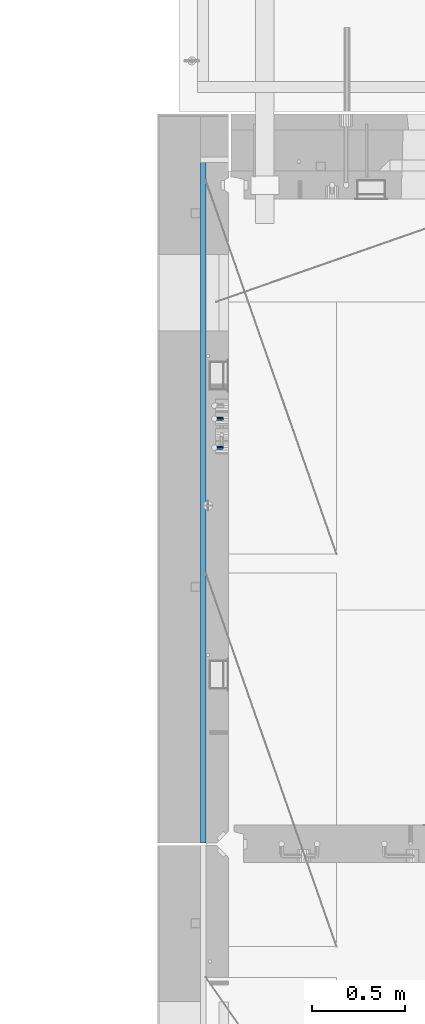
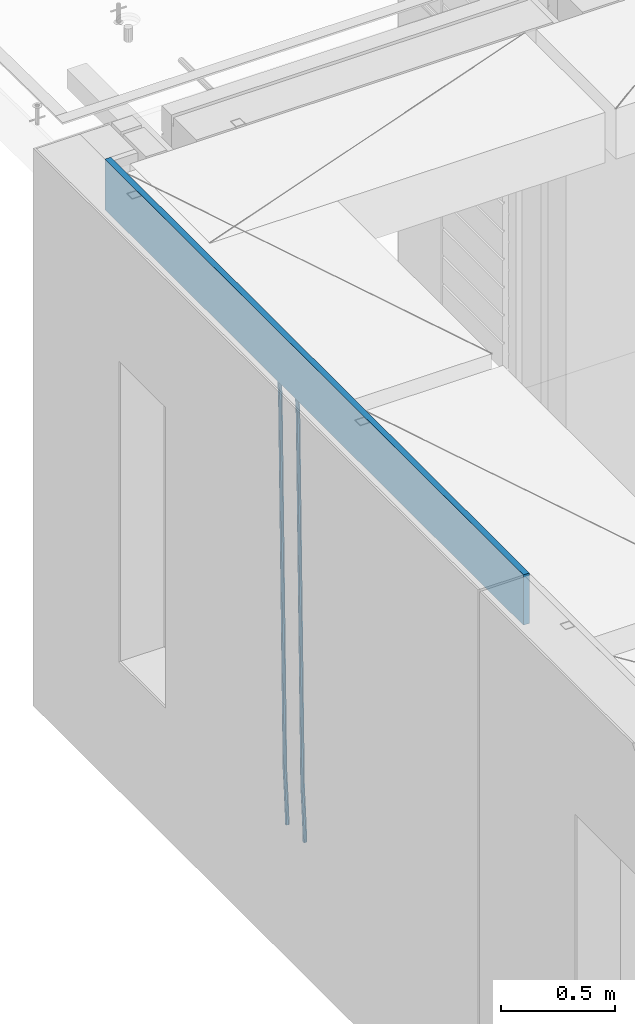
# One storey, part 108 of 341: 3 beams, 1 element without a shape of its own.
"""IFC2X3 building model written with IfcOpenShell, lengths in millimetres."""

from ifc_helpers import new_model, si_unit, frame, origin_with_axes, place, context, subcontext, project, spatial, faceted_brep, material, type_object, element, aggregate, save


model = new_model("IFC2X3")

# Units and contexts
model_context = context("Model", 3, precision=1e-05, world=origin_with_axes())
body_context = subcontext(model_context, "Body", "Model", "MODEL_VIEW")
ifc_project = project(units=[si_unit("LENGTHUNIT", "METRE", prefix="MILLI"), si_unit("AREAUNIT", "SQUARE_METRE"), si_unit("VOLUMEUNIT", "CUBIC_METRE"), si_unit("MASSUNIT", "GRAM", prefix="KILO"), si_unit("TIMEUNIT", "SECOND"), si_unit("PLANEANGLEUNIT", "RADIAN"), si_unit("SOLIDANGLEUNIT", "STERADIAN"), si_unit("THERMODYNAMICTEMPERATUREUNIT", "DEGREE_CELSIUS"), si_unit("LUMINOUSINTENSITYUNIT", "LUMEN")], contexts=[model_context])

# Site, building, storey
site_placement = place(None, origin_with_axes())
site = spatial("IfcSite", under=ifc_project, at=site_placement, CompositionType="ELEMENT")
building_placement = place(site_placement, origin_with_axes())
building = spatial("IfcBuilding", under=site, at=building_placement, CompositionType="ELEMENT")
storey_placement = place(building_placement, origin_with_axes())
storey = spatial("IfcBuildingStorey", under=building, at=storey_placement, Name="5", CompositionType="ELEMENT", Elevation=0.0)

# Assembly, beams
assembly_placement = place(storey_placement, origin_with_axes())
assembly = element("IfcElementAssembly", 1, at=assembly_placement, inside=storey, AssemblyPlace="NOTDEFINED", PredefinedType="REINFORCEMENT_UNIT")
ifc_material_1 = material()
beam_type_1 = type_object("IfcBeamType", Name="D20", PredefinedType="NOTDEFINED")
beam_1_placement = place(assembly_placement, frame((7965.00000455602, 19100.0000000039, 93990.0), z_axis=(-0.999642804636942, -0.000205726999925762, -0.0267249099902983), x_axis=(-0.0267249099948371, 4.30000201934385e-08, 0.999642825806181)))
beam_1 = element("IfcBeam", 2, at=beam_1_placement, type_object=beam_type_1, material=ifc_material_1, Name="JM20", ObjectType="D20", context=body_context, shape_type="Brep", body=[
    faceted_brep([(0.0, -10.0, 0.0), (-4.19531716033816e-08, -7.07106781186667, -7.07106781187031), (60.4266690400545, -7.0710677960451, -7.07106780570757), (60.4266690441291, -9.99999998418934, 6.15546014159918e-09), (0.0, 0.0, -10.0), (60.426669036824, 1.58106558956206e-08, -9.99999999384454), (4.196772351861e-08, 7.07106781186303, -7.07106781186667), (60.4266690363438, 7.07106782768096, -7.07106780570757), (0.0, 10.0, 0.0), (60.4266690388904, 10.0000000158179, 6.15182216279209e-09), (4.196772351861e-08, 7.07106781185939, 7.07106781185939), (60.4266690429649, 7.07106782768096, 7.07106781802577), (0.0, 0.0, 10.0), (60.4266690461809, 1.58179318532348e-08, 10.0000000061555), (-4.19531716033816e-08, -7.07106781187031, 7.07106781185939), (60.4266690466611, -7.07106779605238, 7.07106781802213), (61.0378400410118, -7.07106779588503, -7.07106780564936), (60.991799419251, -9.99999998403655, 6.21366780251265e-09), (61.0569027789461, 1.5985278878361e-08, -9.99999999378269), (61.0378209396877, 7.07106782784831, -7.07106780564936), (60.9917724058905, 10.0000000159635, 6.21366780251265e-09), (60.9457317841297, 7.07106782781193, 7.0710678180767), (60.9266690461809, 1.59488990902901e-08, 10.0000000062028), (60.9457508854539, -7.07106779591413, 7.0710678180767), (61.6489592143771, -7.07106614513759, -7.06310863441468), (61.5568818710308, -9.9999984576425, 0.00735959856683621), (61.6870830769039, 1.71821739058942e-06, -9.99179257185824), (61.6489210170112, 7.07106947854481, -7.06310888312146), (61.556827851804, 10.0000015422847, 0.00735924683976918), (61.4647505084577, 7.07106922979438, 7.07782747982128), (61.4266266459163, 1.36643211590126e-06, 10.0065114172685), (61.464788705809, -7.07106639389531, 7.07782772852806), (176.543135720174, -7.07075579406956, -5.56673531796696), (176.451058376813, -9.99968810657447, 1.50373291501455), (176.581259582701, 0.000312069292704109, -8.49541925541052), (176.543097522794, 7.07137982961285, -5.56673556667374), (176.451004357587, 10.00031189336, 1.50373256329476), (176.35892701424, 7.07137958085514, 8.57420079627263), (176.320803151699, 0.000311717507429421, 11.5028847337162), (176.358965211621, -7.07075604281999, 8.57420104497578), (177.098753836006, -7.07075429323595, -5.55949898843028), (176.98362511232, -9.99968666800123, 1.510669025065), (177.146421932586, 0.000313595905026887, -8.48805862247536), (177.098706077581, 7.07138133041735, -5.55949936166144), (176.983557571715, 10.0003133318824, 1.51066849724157), (176.868428848029, 7.07138095712435, 8.58083651073321), (176.820760751449, 0.000313067976094317, 11.5093961447819), (176.868476606425, -7.07075466652896, 8.58083688396073), (177.654312950661, -7.07075204110879, -5.54863964998367), (177.516135294456, -9.99968450931192, 1.52107783331303), (177.711524267797, 0.000315886711177882, -8.47701274570863), (177.654255632195, 7.07138358250813, -5.54864021007961), (177.516054233929, 10.0003154905207, 1.5210770412159), (177.377876577739, 7.0713830223176, 8.59079452451624), (177.320665260588, 0.000315094497636892, 11.5191676202448), (177.377933896176, -7.07075260129932, 8.59079508461218), (299.436796249574, -7.07025836271714, -3.1681962331204), (299.298618593355, -9.99919083092027, 3.90152125031091), (299.494007566798, 0.000809565110102994, -6.09656932889993), (299.436738931283, 7.07187726089978, -3.16819679320906), (299.298537533061, 10.0008091689197, 3.90152045822106), (299.160359876842, 7.07187670072017, 10.9712379416487), (299.103148559603, 0.000808772889286047, 13.8996110374392), (299.160417195119, -7.07025892290039, 10.9712385017483), (299.98743051647, -7.07025613056248, -3.15743315966392), (299.971788958996, -9.99918809853989, 3.91467979818117), (299.993912075952, 0.000811591617093654, -6.08679785393178), (299.987423933868, 7.07187949325817, -3.1574327280432), (299.971753863239, 10.0008119014747, 3.91467990454839), (299.95611230444, 7.07187992653053, 10.9867922621015), (299.949630744944, 0.000812204350950196, 13.9161569563694), (299.956118887014, -7.07025569729012, 10.9867918304735), (300.538107039494, -7.07025785017686, -3.16575821840888), (300.644985195438, -9.99919020432935, 3.90450175465594), (300.493854948218, 0.000810030429420294, -6.09435592770024), (300.538151196495, 7.071877773491, -3.16575855385963), (300.645047642858, 10.0008097955724, 3.90450128024895), (300.751925798773, 7.07187744142357, 10.9747612533101), (300.796177890064, 0.000809560813650023, 13.9033589625978), (300.751881641787, -7.07025818224065, 10.9747615887682), (2293.36490490142, -7.07648090940347, -33.2930642912361), (2293.47178305736, -10.0054132635523, -26.2228043181785), (2293.32065281013, -0.00541302880083094, -36.2216620005347), (2293.36494905842, 7.06565471425711, -33.2930646266868), (2293.47184550477, 9.99458673634581, -26.2228047925819), (2293.57872366071, 7.06565438219332, -19.1525448195243), (2293.62297575199, -0.00541349841296324, -16.2239471102366), (2293.57867950371, -7.0764812414709, -19.1525444840736), (2294.0658245362, -7.07648309818615, -33.3036607065333), (2294.05312277409, -10.0054150789219, -26.2315929392535), (2294.10928714235, -0.00541549149056664, -36.2335844756526), (2294.15805078732, 7.06565223761572, -33.3050546393533), (2294.18355038921, 9.99458451388637, -26.2335642579346), (2294.17084862708, 7.06565253314329, -19.1614964906439), (2294.12738602093, -0.00541507354500936, -16.2315727215355), (2294.07862237596, -7.07648280265857, -19.1601025578348), (2294.76670261032, -7.08562269121467, -33.294332712383), (2294.63442802057, -10.0129954178956, -26.2238563411993), (2294.89787471293, -0.0156988342423574, -36.2230891548279), (2294.95110548967, 7.05531064255774, -33.2944998654275), (2294.89521307347, 9.98530428734011, -26.2240927312887), (2294.76293848372, 7.0579315606592, -19.1536163601049), (2294.63176638114, -0.0119922963167483, -16.2248599176673), (2294.57853560438, -7.08300177311321, -19.1534492070678), (2316.52657204497, -7.36937582653991, -33.0047303660212), (2316.39429745522, -10.2967485532172, -25.9342539948302), (2316.65774414754, -0.299451969567599, -35.9334868084661), (2316.7109749243, 6.7715575072325, -33.0048975190657), (2316.65508250811, 9.70155115201487, -25.9344903849269), (2316.52280791836, 6.7741784253376, -18.8640140137468), (2316.39163581574, -0.295745431634714, -15.9352575713092), (2316.33840503903, -7.36675490843481, -18.863846860706), (2317.16202064224, -7.37766220584308, -32.9962731735213), (2317.05438744847, -10.3053562613532, -25.9254688497131), (2317.23607125619, -0.306993473008333, -35.925789846493), (2317.23316144495, 6.76474808850253, -32.9979477328052), (2317.15499573652, 9.6950321815566, -25.9278370341635), (2317.04736254275, 6.7673381260538, -18.8570327103698), (2316.97331192881, -0.303330606784584, -15.9275160373909), (2316.97622174003, -7.37507216829545, -18.8553581510787), (2317.79752306276, -7.37578610372293, -32.9880110666527), (2317.71453320107, -10.3033876998124, -25.9168792378296), (2317.81444760226, -0.305295583297266, -35.918287695793), (2317.75539265381, 6.76628640723357, -32.9911928173897), (2317.65495180529, 9.69652304524061, -25.9213789128698), (2317.5719619436, 6.76892144914746, -18.8502470840467), (2317.55503740412, -0.301569071270933, -15.9199704549137), (2317.61409235255, -7.3731510618054, -18.847065333317), (2417.8183084176, -7.07752398473531, -31.6906369377139), (2417.73531855589, -10.0051255808248, -24.6195051088798), (2417.83523295709, -0.007033464313281, -34.6209135668432), (2417.77617800863, 7.06454852621755, -31.6938186884508), (2417.67573716014, 9.99478516423187, -24.6240047839383), (2417.59274729842, 7.06718356813872, -17.5528729551006), (2417.57582275895, -0.00330695228694822, -14.6225963259749), (2417.6348777074, -7.07488894281778, -17.5496912043673)], [[[0, 1, 2, 3]], [[1, 4, 5, 2]], [[4, 6, 7, 5]], [[6, 8, 9, 7]], [[8, 10, 11, 9]], [[10, 12, 13, 11]], [[12, 14, 15, 13]], [[14, 0, 3, 15]], [[14, 12, 10, 8, 6, 4, 1, 0]], [[3, 2, 16, 17]], [[2, 5, 18, 16]], [[5, 7, 19, 18]], [[7, 9, 20, 19]], [[9, 11, 21, 20]], [[11, 13, 22, 21]], [[13, 15, 23, 22]], [[15, 3, 17, 23]], [[17, 16, 24, 25]], [[16, 18, 26, 24]], [[18, 19, 27, 26]], [[19, 20, 28, 27]], [[20, 21, 29, 28]], [[21, 22, 30, 29]], [[22, 23, 31, 30]], [[23, 17, 25, 31]], [[25, 24, 32, 33]], [[24, 26, 34, 32]], [[26, 27, 35, 34]], [[27, 28, 36, 35]], [[28, 29, 37, 36]], [[29, 30, 38, 37]], [[30, 31, 39, 38]], [[31, 25, 33, 39]], [[33, 32, 40, 41]], [[32, 34, 42, 40]], [[34, 35, 43, 42]], [[35, 36, 44, 43]], [[36, 37, 45, 44]], [[37, 38, 46, 45]], [[38, 39, 47, 46]], [[39, 33, 41, 47]], [[41, 40, 48, 49]], [[40, 42, 50, 48]], [[42, 43, 51, 50]], [[43, 44, 52, 51]], [[44, 45, 53, 52]], [[45, 46, 54, 53]], [[46, 47, 55, 54]], [[47, 41, 49, 55]], [[49, 48, 56, 57]], [[48, 50, 58, 56]], [[50, 51, 59, 58]], [[51, 52, 60, 59]], [[52, 53, 61, 60]], [[53, 54, 62, 61]], [[54, 55, 63, 62]], [[55, 49, 57, 63]], [[57, 56, 64, 65]], [[56, 58, 66, 64]], [[58, 59, 67, 66]], [[59, 60, 68, 67]], [[60, 61, 69, 68]], [[61, 62, 70, 69]], [[62, 63, 71, 70]], [[63, 57, 65, 71]], [[65, 64, 72, 73]], [[64, 66, 74, 72]], [[66, 67, 75, 74]], [[67, 68, 76, 75]], [[68, 69, 77, 76]], [[69, 70, 78, 77]], [[70, 71, 79, 78]], [[71, 65, 73, 79]], [[73, 72, 80, 81]], [[72, 74, 82, 80]], [[74, 75, 83, 82]], [[75, 76, 84, 83]], [[76, 77, 85, 84]], [[77, 78, 86, 85]], [[78, 79, 87, 86]], [[79, 73, 81, 87]], [[81, 80, 88, 89]], [[80, 82, 90, 88]], [[82, 83, 91, 90]], [[83, 84, 92, 91]], [[84, 85, 93, 92]], [[85, 86, 94, 93]], [[86, 87, 95, 94]], [[87, 81, 89, 95]], [[89, 88, 96, 97]], [[88, 90, 98, 96]], [[90, 91, 99, 98]], [[91, 92, 100, 99]], [[92, 93, 101, 100]], [[93, 94, 102, 101]], [[94, 95, 103, 102]], [[95, 89, 97, 103]], [[97, 96, 104, 105]], [[96, 98, 106, 104]], [[98, 99, 107, 106]], [[99, 100, 108, 107]], [[100, 101, 109, 108]], [[101, 102, 110, 109]], [[102, 103, 111, 110]], [[103, 97, 105, 111]], [[105, 104, 112, 113]], [[104, 106, 114, 112]], [[106, 107, 115, 114]], [[107, 108, 116, 115]], [[108, 109, 117, 116]], [[109, 110, 118, 117]], [[110, 111, 119, 118]], [[111, 105, 113, 119]], [[113, 112, 120, 121]], [[112, 114, 122, 120]], [[114, 115, 123, 122]], [[115, 116, 124, 123]], [[116, 117, 125, 124]], [[117, 118, 126, 125]], [[118, 119, 127, 126]], [[119, 113, 121, 127]], [[121, 120, 128, 129]], [[120, 122, 130, 128]], [[122, 123, 131, 130]], [[123, 124, 132, 131]], [[124, 125, 133, 132]], [[125, 126, 134, 133]], [[126, 127, 135, 134]], [[127, 121, 129, 135]], [[130, 131, 132, 133, 134, 135, 129, 128]]]),
])
beam_2_placement = place(assembly_placement, frame((7965.00000455602, 19255.0000000039, 93990.0), z_axis=(-0.999642804636942, -0.000205726999925762, -0.0267249099902983), x_axis=(-0.0267249099948371, 4.30000201934385e-08, 0.999642825806181)))
beam_2 = element("IfcBeam", 3, at=beam_2_placement, type_object=beam_type_1, material=ifc_material_1, Name="JM20", ObjectType="D20", context=body_context, shape_type="Brep", body=[
    faceted_brep([(0.0, -10.0, 0.0), (-4.19531716033816e-08, -7.07106781186667, -7.07106781187031), (60.4266690400545, -7.0710677960451, -7.07106780570757), (60.4266690441291, -9.99999998418934, 6.15546014159918e-09), (0.0, 0.0, -10.0), (60.426669036824, 1.58106558956206e-08, -9.99999999384454), (4.196772351861e-08, 7.07106781186303, -7.07106781186667), (60.4266690363438, 7.07106782768096, -7.07106780570757), (0.0, 10.0, 0.0), (60.4266690388904, 10.0000000158179, 6.15182216279209e-09), (4.196772351861e-08, 7.07106781185939, 7.07106781185939), (60.4266690429649, 7.07106782768096, 7.07106781802577), (0.0, 0.0, 10.0), (60.4266690461809, 1.58179318532348e-08, 10.0000000061555), (-4.19531716033816e-08, -7.07106781187031, 7.07106781185939), (60.4266690466611, -7.07106779605238, 7.07106781802213), (61.0378400410118, -7.07106779588503, -7.07106780564936), (60.991799419251, -9.99999998403655, 6.21366780251265e-09), (61.0569027789461, 1.5985278878361e-08, -9.99999999378269), (61.0378209396877, 7.07106782784831, -7.07106780564936), (60.9917724058905, 10.0000000159635, 6.21366780251265e-09), (60.9457317841297, 7.07106782781193, 7.0710678180767), (60.9266690461809, 1.59488990902901e-08, 10.0000000062028), (60.9457508854539, -7.07106779591413, 7.0710678180767), (61.6489592143771, -7.07106614513759, -7.06310863441468), (61.5568818710308, -9.9999984576425, 0.00735959856683621), (61.6870830769039, 1.71821739058942e-06, -9.99179257185824), (61.6489210170112, 7.07106947854481, -7.06310888312146), (61.556827851804, 10.0000015422847, 0.00735924683976918), (61.4647505084577, 7.07106922979438, 7.07782747982128), (61.4266266459163, 1.36643211590126e-06, 10.0065114172685), (61.464788705809, -7.07106639389531, 7.07782772852806), (176.543135720174, -7.07075579406956, -5.56673531796696), (176.451058376813, -9.99968810657447, 1.50373291501455), (176.581259582701, 0.000312069292704109, -8.49541925541052), (176.543097522794, 7.07137982961285, -5.56673556667374), (176.451004357587, 10.00031189336, 1.50373256329476), (176.35892701424, 7.07137958085514, 8.57420079627263), (176.320803151699, 0.000311717507429421, 11.5028847337162), (176.358965211621, -7.07075604281999, 8.57420104497578), (177.098753836006, -7.07075429323595, -5.55949898843028), (176.98362511232, -9.99968666800123, 1.510669025065), (177.146421932586, 0.000313595905026887, -8.48805862247536), (177.098706077581, 7.07138133041735, -5.55949936166144), (176.983557571715, 10.0003133318824, 1.51066849724157), (176.868428848029, 7.07138095712435, 8.58083651073321), (176.820760751449, 0.000313067976094317, 11.5093961447819), (176.868476606425, -7.07075466652896, 8.58083688396073), (177.654312950661, -7.07075204110879, -5.54863964998367), (177.516135294456, -9.99968450931192, 1.52107783331303), (177.711524267797, 0.000315886711177882, -8.47701274570863), (177.654255632195, 7.07138358250813, -5.54864021007961), (177.516054233929, 10.0003154905207, 1.5210770412159), (177.377876577739, 7.0713830223176, 8.59079452451624), (177.320665260588, 0.000315094497636892, 11.5191676202448), (177.377933896176, -7.07075260129932, 8.59079508461218), (299.436796249574, -7.07025836271714, -3.1681962331204), (299.298618593355, -9.99919083092027, 3.90152125031091), (299.494007566798, 0.000809565110102994, -6.09656932889993), (299.436738931283, 7.07187726089978, -3.16819679320906), (299.298537533061, 10.0008091689197, 3.90152045822106), (299.160359876842, 7.07187670072017, 10.9712379416487), (299.103148559603, 0.000808772889286047, 13.8996110374392), (299.160417195119, -7.07025892290039, 10.9712385017483), (299.98743051647, -7.07025613056248, -3.15743315966392), (299.971788958996, -9.99918809853989, 3.91467979818117), (299.993912075952, 0.000811591617093654, -6.08679785393178), (299.987423933868, 7.07187949325817, -3.1574327280432), (299.971753863239, 10.0008119014747, 3.91467990454839), (299.95611230444, 7.07187992653053, 10.9867922621015), (299.949630744944, 0.000812204350950196, 13.9161569563694), (299.956118887014, -7.07025569729012, 10.9867918304735), (300.538107039494, -7.07025785017686, -3.16575821840888), (300.644985195438, -9.99919020432935, 3.90450175465594), (300.493854948218, 0.000810030429420294, -6.09435592770024), (300.538151196495, 7.071877773491, -3.16575855385963), (300.645047642858, 10.0008097955724, 3.90450128024895), (300.751925798773, 7.07187744142357, 10.9747612533101), (300.796177890064, 0.000809560813650023, 13.9033589625978), (300.751881641787, -7.07025818224065, 10.9747615887682), (2293.36490490142, -7.07648090940347, -33.2930642912361), (2293.47178305736, -10.0054132635523, -26.2228043181785), (2293.32065281013, -0.00541302880083094, -36.2216620005347), (2293.36494905842, 7.06565471425711, -33.2930646266868), (2293.47184550477, 9.99458673634581, -26.2228047925819), (2293.57872366071, 7.06565438219332, -19.1525448195243), (2293.62297575199, -0.00541349841296324, -16.2239471102366), (2293.57867950371, -7.0764812414709, -19.1525444840736), (2294.0658245362, -7.07648309818615, -33.3036607065333), (2294.05312277409, -10.0054150789219, -26.2315929392535), (2294.10928714235, -0.00541549149056664, -36.2335844756526), (2294.15805078732, 7.06565223761572, -33.3050546393533), (2294.18355038921, 9.99458451388637, -26.2335642579346), (2294.17084862708, 7.06565253314329, -19.1614964906439), (2294.12738602093, -0.00541507354500936, -16.2315727215355), (2294.07862237596, -7.07648280265857, -19.1601025578348), (2294.76670261032, -7.08562269121467, -33.294332712383), (2294.63442802057, -10.0129954178956, -26.2238563411993), (2294.89787471293, -0.0156988342423574, -36.2230891548279), (2294.95110548967, 7.05531064255774, -33.2944998654275), (2294.89521307347, 9.98530428734011, -26.2240927312887), (2294.76293848372, 7.0579315606592, -19.1536163601049), (2294.63176638114, -0.0119922963167483, -16.2248599176673), (2294.57853560438, -7.08300177311321, -19.1534492070678), (2316.52657204497, -7.36937582653991, -33.0047303660212), (2316.39429745522, -10.2967485532172, -25.9342539948302), (2316.65774414754, -0.299451969567599, -35.9334868084661), (2316.7109749243, 6.7715575072325, -33.0048975190657), (2316.65508250811, 9.70155115201487, -25.9344903849269), (2316.52280791836, 6.7741784253376, -18.8640140137468), (2316.39163581574, -0.295745431634714, -15.9352575713092), (2316.33840503903, -7.36675490843481, -18.863846860706), (2317.16202064224, -7.37766220584308, -32.9962731735213), (2317.05438744847, -10.3053562613532, -25.9254688497131), (2317.23607125619, -0.306993473008333, -35.925789846493), (2317.23316144495, 6.76474808850253, -32.9979477328052), (2317.15499573652, 9.6950321815566, -25.9278370341635), (2317.04736254275, 6.7673381260538, -18.8570327103698), (2316.97331192881, -0.303330606784584, -15.9275160373909), (2316.97622174003, -7.37507216829545, -18.8553581510787), (2317.79752306276, -7.37578610372293, -32.9880110666527), (2317.71453320107, -10.3033876998124, -25.9168792378296), (2317.81444760226, -0.305295583297266, -35.918287695793), (2317.75539265381, 6.76628640723357, -32.9911928173897), (2317.65495180529, 9.69652304524061, -25.9213789128698), (2317.5719619436, 6.76892144914746, -18.8502470840467), (2317.55503740412, -0.301569071270933, -15.9199704549137), (2317.61409235255, -7.3731510618054, -18.847065333317), (2417.8183084176, -7.07752398473531, -31.6906369377139), (2417.73531855589, -10.0051255808248, -24.6195051088798), (2417.83523295709, -0.007033464313281, -34.6209135668432), (2417.77617800863, 7.06454852621755, -31.6938186884508), (2417.67573716014, 9.99478516423187, -24.6240047839383), (2417.59274729842, 7.06718356813872, -17.5528729551006), (2417.57582275895, -0.00330695228694822, -14.6225963259749), (2417.6348777074, -7.07488894281778, -17.5496912043673)], [[[0, 1, 2, 3]], [[1, 4, 5, 2]], [[4, 6, 7, 5]], [[6, 8, 9, 7]], [[8, 10, 11, 9]], [[10, 12, 13, 11]], [[12, 14, 15, 13]], [[14, 0, 3, 15]], [[14, 12, 10, 8, 6, 4, 1, 0]], [[3, 2, 16, 17]], [[2, 5, 18, 16]], [[5, 7, 19, 18]], [[7, 9, 20, 19]], [[9, 11, 21, 20]], [[11, 13, 22, 21]], [[13, 15, 23, 22]], [[15, 3, 17, 23]], [[17, 16, 24, 25]], [[16, 18, 26, 24]], [[18, 19, 27, 26]], [[19, 20, 28, 27]], [[20, 21, 29, 28]], [[21, 22, 30, 29]], [[22, 23, 31, 30]], [[23, 17, 25, 31]], [[25, 24, 32, 33]], [[24, 26, 34, 32]], [[26, 27, 35, 34]], [[27, 28, 36, 35]], [[28, 29, 37, 36]], [[29, 30, 38, 37]], [[30, 31, 39, 38]], [[31, 25, 33, 39]], [[33, 32, 40, 41]], [[32, 34, 42, 40]], [[34, 35, 43, 42]], [[35, 36, 44, 43]], [[36, 37, 45, 44]], [[37, 38, 46, 45]], [[38, 39, 47, 46]], [[39, 33, 41, 47]], [[41, 40, 48, 49]], [[40, 42, 50, 48]], [[42, 43, 51, 50]], [[43, 44, 52, 51]], [[44, 45, 53, 52]], [[45, 46, 54, 53]], [[46, 47, 55, 54]], [[47, 41, 49, 55]], [[49, 48, 56, 57]], [[48, 50, 58, 56]], [[50, 51, 59, 58]], [[51, 52, 60, 59]], [[52, 53, 61, 60]], [[53, 54, 62, 61]], [[54, 55, 63, 62]], [[55, 49, 57, 63]], [[57, 56, 64, 65]], [[56, 58, 66, 64]], [[58, 59, 67, 66]], [[59, 60, 68, 67]], [[60, 61, 69, 68]], [[61, 62, 70, 69]], [[62, 63, 71, 70]], [[63, 57, 65, 71]], [[65, 64, 72, 73]], [[64, 66, 74, 72]], [[66, 67, 75, 74]], [[67, 68, 76, 75]], [[68, 69, 77, 76]], [[69, 70, 78, 77]], [[70, 71, 79, 78]], [[71, 65, 73, 79]], [[73, 72, 80, 81]], [[72, 74, 82, 80]], [[74, 75, 83, 82]], [[75, 76, 84, 83]], [[76, 77, 85, 84]], [[77, 78, 86, 85]], [[78, 79, 87, 86]], [[79, 73, 81, 87]], [[81, 80, 88, 89]], [[80, 82, 90, 88]], [[82, 83, 91, 90]], [[83, 84, 92, 91]], [[84, 85, 93, 92]], [[85, 86, 94, 93]], [[86, 87, 95, 94]], [[87, 81, 89, 95]], [[89, 88, 96, 97]], [[88, 90, 98, 96]], [[90, 91, 99, 98]], [[91, 92, 100, 99]], [[92, 93, 101, 100]], [[93, 94, 102, 101]], [[94, 95, 103, 102]], [[95, 89, 97, 103]], [[97, 96, 104, 105]], [[96, 98, 106, 104]], [[98, 99, 107, 106]], [[99, 100, 108, 107]], [[100, 101, 109, 108]], [[101, 102, 110, 109]], [[102, 103, 111, 110]], [[103, 97, 105, 111]], [[105, 104, 112, 113]], [[104, 106, 114, 112]], [[106, 107, 115, 114]], [[107, 108, 116, 115]], [[108, 109, 117, 116]], [[109, 110, 118, 117]], [[110, 111, 119, 118]], [[111, 105, 113, 119]], [[113, 112, 120, 121]], [[112, 114, 122, 120]], [[114, 115, 123, 122]], [[115, 116, 124, 123]], [[116, 117, 125, 124]], [[117, 118, 126, 125]], [[118, 119, 127, 126]], [[119, 113, 121, 127]], [[121, 120, 128, 129]], [[120, 122, 130, 128]], [[122, 123, 131, 130]], [[123, 124, 132, 131]], [[124, 125, 133, 132]], [[125, 126, 134, 133]], [[126, 127, 135, 134]], [[127, 121, 129, 135]], [[130, 131, 132, 133, 134, 135, 129, 128]]]),
])
ifc_material_2 = material(Name="CONCRETE/C25/30")
beam_type_2 = type_object("IfcBeamType", Name="270X30", PredefinedType="NOTDEFINED")
beam_3_placement = place(assembly_placement, frame((7865.0, 20654.9951872276, 96605.0), z_axis=(0.0, 0.0, 1.0), x_axis=(0.0, -1.0, 0.0)))
beam_3 = element("IfcBeam", 4, at=beam_3_placement, type_object=beam_type_2, material=ifc_material_2, ObjectType="270X30", context=body_context, shape_type="Brep", body=[
    faceted_brep([(0.0, 15.0, -135.0), (0.0, 15.0, 135.0), (3669.99518722759, 15.0, 135.0), (3669.99518722759, 15.0, -135.0), (0.0, -15.0, 135.0), (3669.99518722759, -15.0, 135.0), (0.0, -15.0, -135.0), (3669.99518722759, -15.0, -135.0)], [[[0, 1, 2, 3]], [[1, 4, 5, 2]], [[4, 6, 7, 5]], [[6, 0, 3, 7]], [[5, 7, 3, 2]], [[6, 4, 1, 0]]]),
])
aggregate(assembly, [beam_1, beam_2, beam_3])

save(model, "model.ifc")
